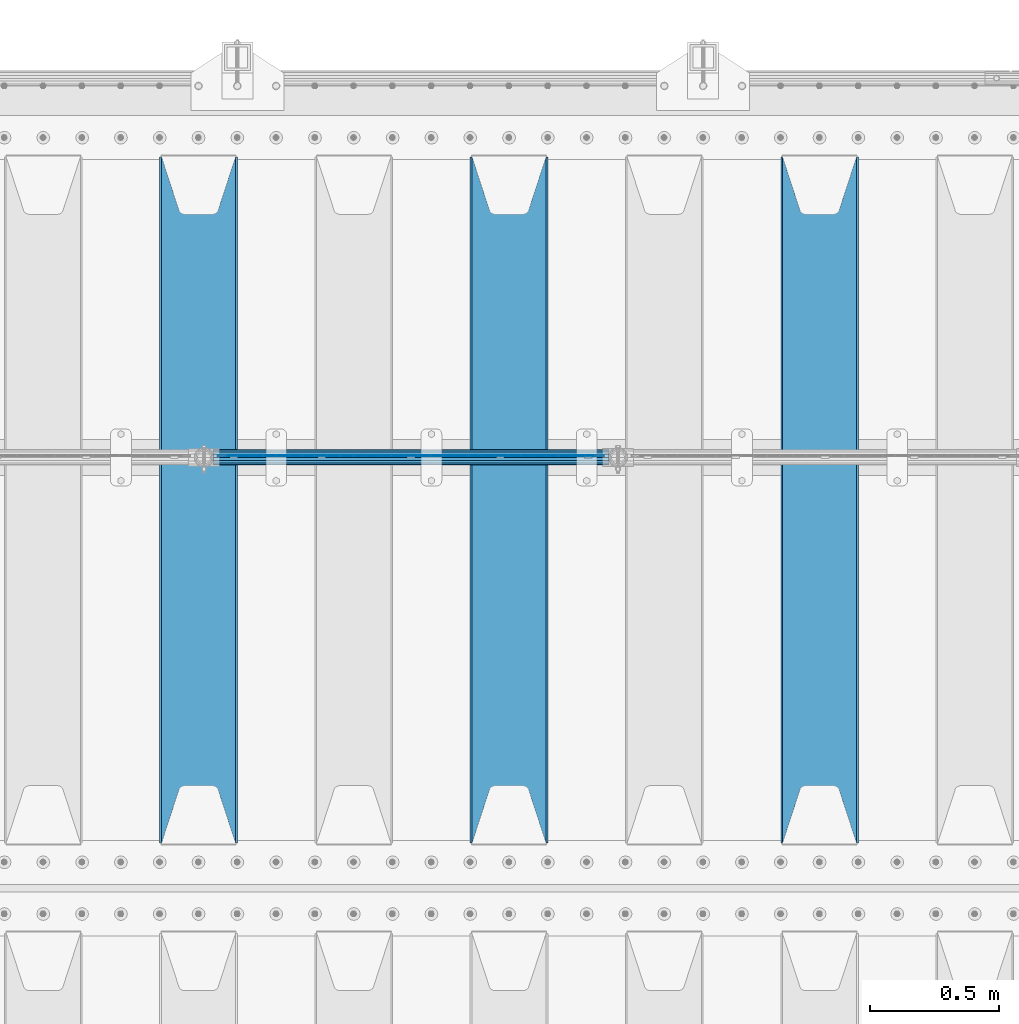
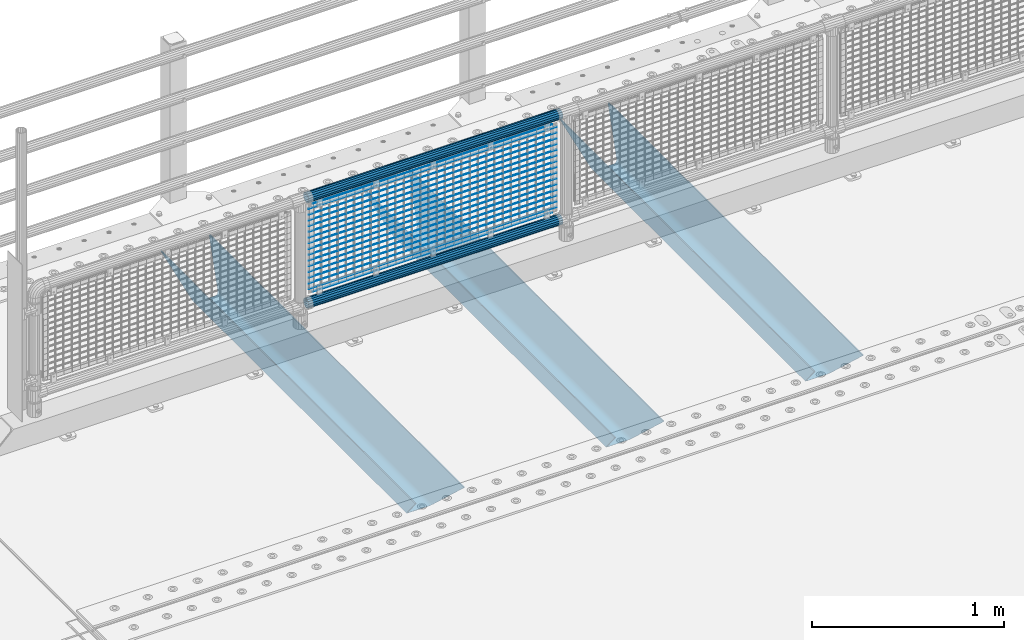
# One storey, part 121 of 247: 22 beams.
"""IFC2X3 building model written with IfcOpenShell, lengths in millimetres."""

from ifc_helpers import new_model, si_unit, frame, origin_with_axes, place, context, subcontext, project, spatial, faceted_brep, material, type_object, element, save


model = new_model("IFC2X3")

# Units and contexts
model_context = context("Model", 3, precision=1e-05, world=origin_with_axes())
body_context = subcontext(model_context, "Body", "Model", "MODEL_VIEW")
ifc_project = project(units=[si_unit("LENGTHUNIT", "METRE", prefix="MILLI"), si_unit("AREAUNIT", "SQUARE_METRE"), si_unit("VOLUMEUNIT", "CUBIC_METRE"), si_unit("MASSUNIT", "GRAM", prefix="KILO"), si_unit("TIMEUNIT", "SECOND"), si_unit("PLANEANGLEUNIT", "RADIAN"), si_unit("SOLIDANGLEUNIT", "STERADIAN"), si_unit("THERMODYNAMICTEMPERATUREUNIT", "DEGREE_CELSIUS"), si_unit("LUMINOUSINTENSITYUNIT", "LUMEN")], contexts=[model_context])

# Site, building, storey
site_placement = place(None, origin_with_axes())
site = spatial("IfcSite", under=ifc_project, at=site_placement, CompositionType="ELEMENT")
building_placement = place(site_placement, origin_with_axes())
building = spatial("IfcBuilding", under=site, at=building_placement, Name="Standard", CompositionType="ELEMENT")
storey_placement = place(building_placement, origin_with_axes())
storey = spatial("IfcBuildingStorey", under=building, at=storey_placement, Name="Undefined", CompositionType="ELEMENT", Elevation=0.0)

# Beams
ifc_material_1 = material(Name="STEEL/S355N")
beam_type_1 = type_object("IfcBeamType", PredefinedType="NOTDEFINED")
beam_1_placement = place(storey_placement, frame((4600.0, 6175.0, -115.0), z_axis=(0.0, 0.0, 1.0), x_axis=(0.0, 1.0, 0.0)))
element("IfcBeam", 1, at=beam_1_placement, inside=storey, type_object=beam_type_1, material=ifc_material_1, context=body_context, shape_type="Brep", body=[
    faceted_brep([(0.0, 150.0, 115.0), (0.0, 143.689999999999, 115.0), (2650.00000000297, 143.689999999999, 115.0), (2650.00000000297, 150.0, 115.0), (2650.00000000297, 142.059565218402, 110.0000000031), (2650.00000000297, 148.369565218403, 110.0000000031), (2441.90079219208, -80.1103600731112, -98.0992078077845), (2437.7588105432, -77.5672621345584, -102.241189456673), (2434.06523489746, -74.4080125315522, -105.934765102404), (2430.91086095089, -70.710272125576, -109.089139048974), (2428.37322971128, -66.5649389910068, -111.626770288588), (2426.51472138054, -62.0739139532889, -113.485278619323), (2425.38102192091, -57.3475956567672, -114.618978078955), (2424.99999999987, -52.5021667386536, -115.0), (2424.99999999987, 52.5021667386536, -115.0), (2425.38102192091, 57.3475956567672, -114.618978078955), (2426.51472138054, 62.0739139532889, -113.485278619323), (2428.37322971128, 66.5649389910068, -111.626770288588), (2430.91086095089, 70.710272125576, -109.089139048974), (2434.06523489746, 74.4080125315522, -105.934765102404), (2437.7588105432, 77.5672621345584, -102.241189456673), (2441.90079219208, 80.1103600731112, -98.0992078077846), (2446.38936140511, 81.9747917625791, -93.6106385947584), (2448.24948500409, 76.2713538057251, -91.7505149957729), (2444.62967112262, 74.76777986261, -95.3703288772456), (2441.28936334126, 72.7168944282894, -98.710636658607), (2438.31067330438, 70.1691124903846, -101.689326695487), (2435.76682334747, 67.1870637758839, -104.233176652398), (2433.72034654133, 63.8440531834895, -106.279653458539), (2432.22154950041, 60.222258798236, -107.778450499454), (2431.30727574265, 56.4107117849089, -108.692724257221), (2430.99999999987, 52.5031078186876, -109.0), (2430.99999999987, -52.5031078186876, -109.0), (2431.30727574265, -56.4107117849089, -108.692724257221), (2432.22154950041, -60.222258798236, -107.778450499454), (2433.72034654133, -63.8440531834895, -106.279653458539), (2435.76682334747, -67.1870637758839, -104.233176652398), (2438.31067330438, -70.1691124903846, -101.689326695487), (2441.28936334126, -72.7168944282894, -98.7106366586071), (2444.62967112262, -74.76777986261, -95.3703288772457), (2448.24948500409, -76.2713538057251, -91.7505149957729), (2650.00000000297, -142.059565218402, 110.0000000031), (2650.00000000297, -148.369565218403, 110.0000000031), (2446.38936140511, -81.9747917625791, -93.6106385947584), (2650.00000000297, -143.689999999999, 115.0), (2650.00000000297, -150.0, 115.0), (0.0, -143.689999999999, 115.0), (0.0, -150.0, 115.0), (0.0, -148.369565218261, 110.000000002663), (203.610638597422, -81.9747917625791, -93.6106385947584), (208.099207810448, -80.1103600731112, -98.0992078077845), (212.241189459336, -77.5672621345584, -102.241189456673), (215.934765105068, -74.4080125315522, -105.934765102404), (219.089139051637, -70.710272125576, -109.089139048974), (221.626770291251, -66.5649389910068, -111.626770288588), (223.485278621985, -62.0739139532889, -113.485278619323), (224.618978081617, -57.3475956567672, -114.618978078955), (225.000000002663, -52.5021667386536, -115.0), (225.000000002663, 52.5021667386536, -115.0), (224.618978081617, 57.3475956567672, -114.618978078955), (223.485278621985, 62.0739139532889, -113.485278619323), (221.626770291251, 66.5649389910068, -111.626770288588), (219.089139051637, 70.710272125576, -109.089139048974), (215.934765105068, 74.4080125315522, -105.934765102404), (212.241189459336, 77.5672621345584, -102.241189456673), (208.099207810448, 80.1103600731112, -98.0992078077846), (203.610638597422, 81.9747917625791, -93.6106385947584), (0.0, 148.369565218261, 110.000000002663), (0.0, 142.05956521826, 110.000000002663), (201.750514998436, 76.2713538057251, -91.7505149957729), (205.370328879908, 74.76777986261, -95.3703288772456), (208.710636661271, 72.7168944282894, -98.710636658607), (211.68932669815, 70.1691124903846, -101.689326695487), (214.233176655061, 67.1870637758839, -104.233176652398), (216.279653461202, 63.8440531834895, -106.279653458539), (217.778450502117, 60.222258798236, -107.778450499454), (218.692724259885, 56.4107117849089, -108.692724257221), (219.000000002663, 52.5031078186876, -109.0), (219.000000002663, -52.5031078186876, -109.0), (218.692724259885, -56.4107117849089, -108.692724257221), (217.778450502117, -60.222258798236, -107.778450499454), (216.279653461202, -63.8440531834895, -106.279653458539), (214.233176655061, -67.1870637758839, -104.233176652398), (211.68932669815, -70.1691124903846, -101.689326695487), (208.710636661271, -72.7168944282894, -98.7106366586071), (205.370328879908, -74.76777986261, -95.3703288772457), (201.750514998436, -76.2713538057251, -91.7505149957729), (0.0, -142.05956521826, 110.000000002663)], [[[0, 1, 2, 3]], [[3, 2, 4, 5]], [[6, 7, 8, 9, 10, 11, 12, 13, 14, 15, 16, 17, 18, 19, 20, 21, 22, 5, 4, 23, 24, 25, 26, 27, 28, 29, 30, 31, 32, 33, 34, 35, 36, 37, 38, 39, 40, 41, 42, 43]], [[44, 45, 42, 41]], [[46, 47, 45, 44]], [[43, 42, 45, 47, 48, 49]], [[6, 43, 49, 50]], [[7, 6, 50, 51]], [[8, 7, 51, 52]], [[9, 8, 52, 53]], [[10, 9, 53, 54]], [[11, 10, 54, 55]], [[12, 11, 55, 56]], [[13, 12, 56, 57]], [[14, 13, 57, 58]], [[15, 14, 58, 59]], [[16, 15, 59, 60]], [[17, 16, 60, 61]], [[18, 17, 61, 62]], [[19, 18, 62, 63]], [[20, 19, 63, 64]], [[21, 20, 64, 65]], [[22, 21, 65, 66]], [[0, 3, 5, 22, 66, 67]], [[1, 0, 67, 68]], [[23, 4, 2, 1, 68, 69]], [[24, 23, 69, 70]], [[25, 24, 70, 71]], [[26, 25, 71, 72]], [[27, 26, 72, 73]], [[28, 27, 73, 74]], [[29, 28, 74, 75]], [[30, 29, 75, 76]], [[31, 30, 76, 77]], [[32, 31, 77, 78]], [[33, 32, 78, 79]], [[34, 33, 79, 80]], [[35, 34, 80, 81]], [[36, 35, 81, 82]], [[37, 36, 82, 83]], [[38, 37, 83, 84]], [[39, 38, 84, 85]], [[40, 39, 85, 86]], [[46, 44, 41, 40, 86, 87]], [[47, 46, 87, 48]], [[86, 85, 84, 83, 82, 81, 80, 79, 78, 77, 76, 75, 74, 73, 72, 71, 70, 69, 68, 67, 66, 65, 64, 63, 62, 61, 60, 59, 58, 57, 56, 55, 54, 53, 52, 51, 50, 49, 48, 87]]]),
])
beam_2_placement = place(storey_placement, frame((3400.0, 6175.0, -115.0), z_axis=(0.0, 0.0, 1.0), x_axis=(0.0, 1.0, 0.0)))
element("IfcBeam", 2, at=beam_2_placement, inside=storey, type_object=beam_type_1, material=ifc_material_1, context=body_context, shape_type="Brep", body=[
    faceted_brep([(0.0, 150.0, 115.0), (0.0, 143.689999999999, 115.0), (2650.00000000297, 143.689999999999, 115.0), (2650.00000000297, 150.0, 115.0), (2650.00000000297, 142.059565218402, 110.0000000031), (2650.00000000297, 148.369565218403, 110.0000000031), (2441.90079219208, -80.1103600731112, -98.0992078077845), (2437.7588105432, -77.5672621345584, -102.241189456673), (2434.06523489746, -74.4080125315522, -105.934765102404), (2430.91086095089, -70.710272125576, -109.089139048974), (2428.37322971128, -66.5649389910068, -111.626770288588), (2426.51472138054, -62.0739139532889, -113.485278619323), (2425.38102192091, -57.3475956567672, -114.618978078955), (2424.99999999987, -52.5021667386536, -115.0), (2424.99999999987, 52.5021667386536, -115.0), (2425.38102192091, 57.3475956567672, -114.618978078955), (2426.51472138054, 62.0739139532889, -113.485278619323), (2428.37322971128, 66.5649389910068, -111.626770288588), (2430.91086095089, 70.710272125576, -109.089139048974), (2434.06523489746, 74.4080125315522, -105.934765102404), (2437.7588105432, 77.5672621345584, -102.241189456673), (2441.90079219208, 80.1103600731112, -98.0992078077846), (2446.38936140511, 81.9747917625791, -93.6106385947584), (2448.24948500409, 76.2713538057251, -91.7505149957729), (2444.62967112262, 74.76777986261, -95.3703288772456), (2441.28936334126, 72.7168944282894, -98.710636658607), (2438.31067330438, 70.1691124903846, -101.689326695487), (2435.76682334747, 67.1870637758839, -104.233176652398), (2433.72034654133, 63.8440531834895, -106.279653458539), (2432.22154950041, 60.222258798236, -107.778450499454), (2431.30727574265, 56.4107117849089, -108.692724257221), (2430.99999999987, 52.5031078186876, -109.0), (2430.99999999987, -52.5031078186876, -109.0), (2431.30727574265, -56.4107117849089, -108.692724257221), (2432.22154950041, -60.222258798236, -107.778450499454), (2433.72034654133, -63.8440531834895, -106.279653458539), (2435.76682334747, -67.1870637758839, -104.233176652398), (2438.31067330438, -70.1691124903846, -101.689326695487), (2441.28936334126, -72.7168944282894, -98.7106366586071), (2444.62967112262, -74.76777986261, -95.3703288772457), (2448.24948500409, -76.2713538057251, -91.7505149957729), (2650.00000000297, -142.059565218402, 110.0000000031), (2650.00000000297, -148.369565218403, 110.0000000031), (2446.38936140511, -81.9747917625791, -93.6106385947584), (2650.00000000297, -143.689999999999, 115.0), (2650.00000000297, -150.0, 115.0), (0.0, -143.689999999999, 115.0), (0.0, -150.0, 115.0), (0.0, -148.369565218261, 110.000000002663), (203.610638597422, -81.9747917625791, -93.6106385947584), (208.099207810448, -80.1103600731112, -98.0992078077845), (212.241189459336, -77.5672621345584, -102.241189456673), (215.934765105068, -74.4080125315522, -105.934765102404), (219.089139051637, -70.710272125576, -109.089139048974), (221.626770291251, -66.5649389910068, -111.626770288588), (223.485278621985, -62.0739139532889, -113.485278619323), (224.618978081617, -57.3475956567672, -114.618978078955), (225.000000002663, -52.5021667386536, -115.0), (225.000000002663, 52.5021667386536, -115.0), (224.618978081617, 57.3475956567672, -114.618978078955), (223.485278621985, 62.0739139532889, -113.485278619323), (221.626770291251, 66.5649389910068, -111.626770288588), (219.089139051637, 70.710272125576, -109.089139048974), (215.934765105068, 74.4080125315522, -105.934765102404), (212.241189459336, 77.5672621345584, -102.241189456673), (208.099207810448, 80.1103600731112, -98.0992078077846), (203.610638597422, 81.9747917625791, -93.6106385947584), (0.0, 148.369565218261, 110.000000002663), (0.0, 142.05956521826, 110.000000002663), (201.750514998436, 76.2713538057251, -91.7505149957729), (205.370328879908, 74.76777986261, -95.3703288772456), (208.710636661271, 72.7168944282894, -98.710636658607), (211.68932669815, 70.1691124903846, -101.689326695487), (214.233176655061, 67.1870637758839, -104.233176652398), (216.279653461202, 63.8440531834895, -106.279653458539), (217.778450502117, 60.222258798236, -107.778450499454), (218.692724259885, 56.4107117849089, -108.692724257221), (219.000000002663, 52.5031078186876, -109.0), (219.000000002663, -52.5031078186876, -109.0), (218.692724259885, -56.4107117849089, -108.692724257221), (217.778450502117, -60.222258798236, -107.778450499454), (216.279653461202, -63.8440531834895, -106.279653458539), (214.233176655061, -67.1870637758839, -104.233176652398), (211.68932669815, -70.1691124903846, -101.689326695487), (208.710636661271, -72.7168944282894, -98.7106366586071), (205.370328879908, -74.76777986261, -95.3703288772457), (201.750514998436, -76.2713538057251, -91.7505149957729), (0.0, -142.05956521826, 110.000000002663)], [[[0, 1, 2, 3]], [[3, 2, 4, 5]], [[6, 7, 8, 9, 10, 11, 12, 13, 14, 15, 16, 17, 18, 19, 20, 21, 22, 5, 4, 23, 24, 25, 26, 27, 28, 29, 30, 31, 32, 33, 34, 35, 36, 37, 38, 39, 40, 41, 42, 43]], [[44, 45, 42, 41]], [[46, 47, 45, 44]], [[43, 42, 45, 47, 48, 49]], [[6, 43, 49, 50]], [[7, 6, 50, 51]], [[8, 7, 51, 52]], [[9, 8, 52, 53]], [[10, 9, 53, 54]], [[11, 10, 54, 55]], [[12, 11, 55, 56]], [[13, 12, 56, 57]], [[14, 13, 57, 58]], [[15, 14, 58, 59]], [[16, 15, 59, 60]], [[17, 16, 60, 61]], [[18, 17, 61, 62]], [[19, 18, 62, 63]], [[20, 19, 63, 64]], [[21, 20, 64, 65]], [[22, 21, 65, 66]], [[0, 3, 5, 22, 66, 67]], [[1, 0, 67, 68]], [[23, 4, 2, 1, 68, 69]], [[24, 23, 69, 70]], [[25, 24, 70, 71]], [[26, 25, 71, 72]], [[27, 26, 72, 73]], [[28, 27, 73, 74]], [[29, 28, 74, 75]], [[30, 29, 75, 76]], [[31, 30, 76, 77]], [[32, 31, 77, 78]], [[33, 32, 78, 79]], [[34, 33, 79, 80]], [[35, 34, 80, 81]], [[36, 35, 81, 82]], [[37, 36, 82, 83]], [[38, 37, 83, 84]], [[39, 38, 84, 85]], [[40, 39, 85, 86]], [[46, 44, 41, 40, 86, 87]], [[47, 46, 87, 48]], [[86, 85, 84, 83, 82, 81, 80, 79, 78, 77, 76, 75, 74, 73, 72, 71, 70, 69, 68, 67, 66, 65, 64, 63, 62, 61, 60, 59, 58, 57, 56, 55, 54, 53, 52, 51, 50, 49, 48, 87]]]),
])
beam_3_placement = place(storey_placement, frame((2200.0, 6175.0, -115.0), z_axis=(0.0, 0.0, 1.0), x_axis=(0.0, 1.0, 0.0)))
element("IfcBeam", 3, at=beam_3_placement, inside=storey, type_object=beam_type_1, material=ifc_material_1, context=body_context, shape_type="Brep", body=[
    faceted_brep([(0.0, 150.0, 115.0), (0.0, 143.689999999999, 115.0), (2650.00000000297, 143.689999999999, 115.0), (2650.00000000297, 150.0, 115.0), (2650.00000000297, 142.059565218402, 110.0000000031), (2650.00000000297, 148.369565218403, 110.0000000031), (2441.90079219208, -80.1103600731112, -98.0992078077845), (2437.7588105432, -77.5672621345584, -102.241189456673), (2434.06523489746, -74.4080125315522, -105.934765102404), (2430.91086095089, -70.710272125576, -109.089139048974), (2428.37322971128, -66.5649389910068, -111.626770288588), (2426.51472138054, -62.0739139532889, -113.485278619323), (2425.38102192091, -57.3475956567672, -114.618978078955), (2424.99999999987, -52.5021667386536, -115.0), (2424.99999999987, 52.5021667386536, -115.0), (2425.38102192091, 57.3475956567672, -114.618978078955), (2426.51472138054, 62.0739139532889, -113.485278619323), (2428.37322971128, 66.5649389910068, -111.626770288588), (2430.91086095089, 70.710272125576, -109.089139048974), (2434.06523489746, 74.4080125315522, -105.934765102404), (2437.7588105432, 77.5672621345584, -102.241189456673), (2441.90079219208, 80.1103600731112, -98.0992078077846), (2446.38936140511, 81.9747917625791, -93.6106385947584), (2448.24948500409, 76.2713538057251, -91.7505149957729), (2444.62967112262, 74.76777986261, -95.3703288772456), (2441.28936334126, 72.7168944282894, -98.710636658607), (2438.31067330438, 70.1691124903846, -101.689326695487), (2435.76682334747, 67.1870637758839, -104.233176652398), (2433.72034654133, 63.8440531834895, -106.279653458539), (2432.22154950041, 60.222258798236, -107.778450499454), (2431.30727574265, 56.4107117849089, -108.692724257221), (2430.99999999987, 52.5031078186876, -109.0), (2430.99999999987, -52.5031078186876, -109.0), (2431.30727574265, -56.4107117849089, -108.692724257221), (2432.22154950041, -60.222258798236, -107.778450499454), (2433.72034654133, -63.8440531834895, -106.279653458539), (2435.76682334747, -67.1870637758839, -104.233176652398), (2438.31067330438, -70.1691124903846, -101.689326695487), (2441.28936334126, -72.7168944282894, -98.7106366586071), (2444.62967112262, -74.76777986261, -95.3703288772457), (2448.24948500409, -76.2713538057251, -91.7505149957729), (2650.00000000297, -142.059565218402, 110.0000000031), (2650.00000000297, -148.369565218403, 110.0000000031), (2446.38936140511, -81.9747917625791, -93.6106385947584), (2650.00000000297, -143.689999999999, 115.0), (2650.00000000297, -150.0, 115.0), (0.0, -143.689999999999, 115.0), (0.0, -150.0, 115.0), (0.0, -148.369565218261, 110.000000002663), (203.610638597422, -81.9747917625791, -93.6106385947584), (208.099207810448, -80.1103600731112, -98.0992078077845), (212.241189459336, -77.5672621345584, -102.241189456673), (215.934765105068, -74.4080125315522, -105.934765102404), (219.089139051637, -70.710272125576, -109.089139048974), (221.626770291251, -66.5649389910068, -111.626770288588), (223.485278621985, -62.0739139532889, -113.485278619323), (224.618978081617, -57.3475956567672, -114.618978078955), (225.000000002663, -52.5021667386536, -115.0), (225.000000002663, 52.5021667386536, -115.0), (224.618978081617, 57.3475956567672, -114.618978078955), (223.485278621985, 62.0739139532889, -113.485278619323), (221.626770291251, 66.5649389910068, -111.626770288588), (219.089139051637, 70.710272125576, -109.089139048974), (215.934765105068, 74.4080125315522, -105.934765102404), (212.241189459336, 77.5672621345584, -102.241189456673), (208.099207810448, 80.1103600731112, -98.0992078077846), (203.610638597422, 81.9747917625791, -93.6106385947584), (0.0, 148.369565218261, 110.000000002663), (0.0, 142.05956521826, 110.000000002663), (201.750514998436, 76.2713538057251, -91.7505149957729), (205.370328879908, 74.76777986261, -95.3703288772456), (208.710636661271, 72.7168944282894, -98.710636658607), (211.68932669815, 70.1691124903846, -101.689326695487), (214.233176655061, 67.1870637758839, -104.233176652398), (216.279653461202, 63.8440531834895, -106.279653458539), (217.778450502117, 60.222258798236, -107.778450499454), (218.692724259885, 56.4107117849089, -108.692724257221), (219.000000002663, 52.5031078186876, -109.0), (219.000000002663, -52.5031078186876, -109.0), (218.692724259885, -56.4107117849089, -108.692724257221), (217.778450502117, -60.222258798236, -107.778450499454), (216.279653461202, -63.8440531834895, -106.279653458539), (214.233176655061, -67.1870637758839, -104.233176652398), (211.68932669815, -70.1691124903846, -101.689326695487), (208.710636661271, -72.7168944282894, -98.7106366586071), (205.370328879908, -74.76777986261, -95.3703288772457), (201.750514998436, -76.2713538057251, -91.7505149957729), (0.0, -142.05956521826, 110.000000002663)], [[[0, 1, 2, 3]], [[3, 2, 4, 5]], [[6, 7, 8, 9, 10, 11, 12, 13, 14, 15, 16, 17, 18, 19, 20, 21, 22, 5, 4, 23, 24, 25, 26, 27, 28, 29, 30, 31, 32, 33, 34, 35, 36, 37, 38, 39, 40, 41, 42, 43]], [[44, 45, 42, 41]], [[46, 47, 45, 44]], [[43, 42, 45, 47, 48, 49]], [[6, 43, 49, 50]], [[7, 6, 50, 51]], [[8, 7, 51, 52]], [[9, 8, 52, 53]], [[10, 9, 53, 54]], [[11, 10, 54, 55]], [[12, 11, 55, 56]], [[13, 12, 56, 57]], [[14, 13, 57, 58]], [[15, 14, 58, 59]], [[16, 15, 59, 60]], [[17, 16, 60, 61]], [[18, 17, 61, 62]], [[19, 18, 62, 63]], [[20, 19, 63, 64]], [[21, 20, 64, 65]], [[22, 21, 65, 66]], [[0, 3, 5, 22, 66, 67]], [[1, 0, 67, 68]], [[23, 4, 2, 1, 68, 69]], [[24, 23, 69, 70]], [[25, 24, 70, 71]], [[26, 25, 71, 72]], [[27, 26, 72, 73]], [[28, 27, 73, 74]], [[29, 28, 74, 75]], [[30, 29, 75, 76]], [[31, 30, 76, 77]], [[32, 31, 77, 78]], [[33, 32, 78, 79]], [[34, 33, 79, 80]], [[35, 34, 80, 81]], [[36, 35, 81, 82]], [[37, 36, 82, 83]], [[38, 37, 83, 84]], [[39, 38, 84, 85]], [[40, 39, 85, 86]], [[46, 44, 41, 40, 86, 87]], [[47, 46, 87, 48]], [[86, 85, 84, 83, 82, 81, 80, 79, 78, 77, 76, 75, 74, 73, 72, 71, 70, 69, 68, 67, 66, 65, 64, 63, 62, 61, 60, 59, 58, 57, 56, 55, 54, 53, 52, 51, 50, 49, 48, 87]]]),
])
ifc_material_2 = material()
beam_type_2 = type_object("IfcBeamType", PredefinedType="NOTDEFINED")
beam_4_placement = place(storey_placement, frame((2255.85000000001, 7664.5, 298.170000000001), z_axis=(0.0, 0.0, 1.0), x_axis=(1.0, 0.0, 0.0)))
element("IfcBeam", 4, at=beam_4_placement, inside=storey, type_object=beam_type_2, material=ifc_material_2, context=body_context, shape_type="Brep", body=[
    faceted_brep([(0.0, -25.3500000000004, 0.0), (0.0, -23.4203461491616, 9.70102501045585), (1530.0, -23.4203461491616, 9.70102501045506), (1530.0, -25.3500000000004, 0.0), (0.0, -17.9251569030794, 17.9251569030785), (1530.0, -17.9251569030794, 17.925156903079), (0.0, -9.70102501045494, 23.4203461491616), (1530.0, -9.70102501045494, 23.4203461491611), (0.0, 0.0, 25.3500000000004), (1530.0, 0.0, 25.35), (0.0, 9.70102501045494, 23.4203461491616), (1530.0, 9.70102501045494, 23.4203461491611), (0.0, 17.9251569030794, 17.9251569030785), (1530.0, 17.9251569030794, 17.925156903079), (0.0, 23.4203461491616, 9.70102501045585), (1530.0, 23.4203461491616, 9.70102501045506), (0.0, 25.3500000000004, 0.0), (1530.0, 25.3500000000004, 0.0), (0.0, 23.4203461491616, -9.70102501045585), (1530.0, 23.4203461491616, -9.70102501045506), (0.0, 17.9251569030794, -17.9251569030785), (1530.0, 17.9251569030794, -17.925156903079), (0.0, 9.70102501045494, -23.4203461491616), (1530.0, 9.70102501045494, -23.4203461491611), (0.0, 0.0, -25.3500000000004), (1530.0, 0.0, -25.35), (0.0, -9.70102501045494, -23.4203461491616), (1530.0, -9.70102501045494, -23.4203461491611), (0.0, -17.9251569030794, -17.9251569030785), (1530.0, -17.9251569030794, -17.925156903079), (0.0, -23.4203461491616, -9.70102501045585), (1530.0, -23.4203461491616, -9.70102501045506), (0.0, -30.1499999999996, 0.0), (0.0, -27.8549679052148, -11.5379054858076), (1530.0, -27.8549679052148, -11.5379054858075), (1530.0, -30.1499999999996, 0.0), (0.0, -21.3192694527743, -21.3192694527752), (1530.0, -21.3192694527743, -21.3192694527744), (0.0, -11.5379054858076, -27.8549679052157), (1530.0, -11.5379054858076, -27.8549679052153), (0.0, 0.0, -30.1499999999996), (1530.0, 0.0, -30.15), (0.0, 11.5379054858076, -27.8549679052157), (1530.0, 11.5379054858076, -27.8549679052153), (0.0, 21.3192694527743, -21.3192694527752), (1530.0, 21.3192694527743, -21.3192694527744), (0.0, 27.8549679052157, -11.5379054858076), (1530.0, 27.8549679052157, -11.5379054858074), (0.0, 30.1499999999996, 0.0), (1530.0, 30.1499999999996, 0.0), (0.0, 27.8549679052157, 11.5379054858076), (1530.0, 27.8549679052157, 11.5379054858074), (0.0, 21.3192694527743, 21.3192694527752), (1530.0, 21.3192694527743, 21.3192694527744), (0.0, 11.5379054858076, 27.8549679052157), (1530.0, 11.5379054858076, 27.8549679052153), (0.0, 0.0, 30.1499999999996), (1530.0, 0.0, 30.15), (0.0, -11.5379054858076, 27.8549679052157), (1530.0, -11.5379054858076, 27.8549679052153), (0.0, -21.3192694527743, 21.3192694527752), (1530.0, -21.3192694527743, 21.3192694527744), (0.0, -27.8549679052157, 11.5379054858076), (1530.0, -27.8549679052157, 11.5379054858074)], [[[0, 1, 2, 3]], [[1, 4, 5, 2]], [[4, 6, 7, 5]], [[6, 8, 9, 7]], [[8, 10, 11, 9]], [[10, 12, 13, 11]], [[12, 14, 15, 13]], [[14, 16, 17, 15]], [[16, 18, 19, 17]], [[18, 20, 21, 19]], [[20, 22, 23, 21]], [[22, 24, 25, 23]], [[24, 26, 27, 25]], [[26, 28, 29, 27]], [[28, 30, 31, 29]], [[30, 0, 3, 31]], [[32, 33, 34, 35]], [[33, 36, 37, 34]], [[36, 38, 39, 37]], [[38, 40, 41, 39]], [[40, 42, 43, 41]], [[42, 44, 45, 43]], [[44, 46, 47, 45]], [[46, 48, 49, 47]], [[48, 50, 51, 49]], [[50, 52, 53, 51]], [[52, 54, 55, 53]], [[54, 56, 57, 55]], [[56, 58, 59, 57]], [[58, 60, 61, 59]], [[60, 62, 63, 61]], [[62, 32, 35, 63]], [[37, 39, 41, 43, 45, 47, 49, 51, 53, 55, 57, 59, 61, 63, 35, 34], [5, 7, 9, 11, 13, 15, 17, 19, 21, 23, 25, 27, 29, 31, 3, 2]], [[62, 60, 58, 56, 54, 52, 50, 48, 46, 44, 42, 40, 38, 36, 33, 32], [30, 28, 26, 24, 22, 20, 18, 16, 14, 12, 10, 8, 6, 4, 1, 0]]]),
])
beam_5_placement = place(storey_placement, frame((2255.85, 7664.5, 969.849999999999), z_axis=(0.0, 0.0, 1.0), x_axis=(1.0, 0.0, 0.0)))
element("IfcBeam", 5, at=beam_5_placement, inside=storey, type_object=beam_type_2, material=ifc_material_2, context=body_context, shape_type="Brep", body=[
    faceted_brep([(0.0, -25.3500000000004, 0.0), (0.0, -23.4203461491616, 9.70102501045585), (1530.0, -23.4203461491616, 9.70102501045506), (1530.0, -25.3500000000004, 0.0), (0.0, -17.9251569030794, 17.9251569030785), (1530.0, -17.9251569030794, 17.925156903079), (0.0, -9.70102501045494, 23.4203461491616), (1530.0, -9.70102501045494, 23.4203461491611), (0.0, 0.0, 25.3500000000004), (1530.0, 0.0, 25.35), (0.0, 9.70102501045494, 23.4203461491616), (1530.0, 9.70102501045494, 23.4203461491611), (0.0, 17.9251569030794, 17.9251569030785), (1530.0, 17.9251569030794, 17.925156903079), (0.0, 23.4203461491616, 9.70102501045585), (1530.0, 23.4203461491616, 9.70102501045506), (0.0, 25.3500000000004, 0.0), (1530.0, 25.3500000000004, 0.0), (0.0, 23.4203461491616, -9.70102501045585), (1530.0, 23.4203461491616, -9.70102501045506), (0.0, 17.9251569030794, -17.9251569030785), (1530.0, 17.9251569030794, -17.925156903079), (0.0, 9.70102501045494, -23.4203461491616), (1530.0, 9.70102501045494, -23.4203461491611), (0.0, 0.0, -25.3500000000004), (1530.0, 0.0, -25.35), (0.0, -9.70102501045494, -23.4203461491616), (1530.0, -9.70102501045494, -23.4203461491611), (0.0, -17.9251569030794, -17.9251569030785), (1530.0, -17.9251569030794, -17.925156903079), (0.0, -23.4203461491616, -9.70102501045585), (1530.0, -23.4203461491616, -9.70102501045506), (0.0, -30.1499999999996, 0.0), (0.0, -27.8549679052148, -11.5379054858076), (1530.0, -27.8549679052148, -11.5379054858075), (1530.0, -30.1499999999996, 0.0), (0.0, -21.3192694527743, -21.3192694527752), (1530.0, -21.3192694527743, -21.3192694527744), (0.0, -11.5379054858076, -27.8549679052157), (1530.0, -11.5379054858076, -27.8549679052153), (0.0, 0.0, -30.1499999999996), (1530.0, 0.0, -30.15), (0.0, 11.5379054858076, -27.8549679052157), (1530.0, 11.5379054858076, -27.8549679052153), (0.0, 21.3192694527743, -21.3192694527752), (1530.0, 21.3192694527743, -21.3192694527744), (0.0, 27.8549679052157, -11.5379054858076), (1530.0, 27.8549679052157, -11.5379054858074), (0.0, 30.1499999999996, 0.0), (1530.0, 30.1499999999996, 0.0), (0.0, 27.8549679052157, 11.5379054858076), (1530.0, 27.8549679052157, 11.5379054858074), (0.0, 21.3192694527743, 21.3192694527752), (1530.0, 21.3192694527743, 21.3192694527744), (0.0, 11.5379054858076, 27.8549679052157), (1530.0, 11.5379054858076, 27.8549679052153), (0.0, 0.0, 30.1499999999996), (1530.0, 0.0, 30.15), (0.0, -11.5379054858076, 27.8549679052157), (1530.0, -11.5379054858076, 27.8549679052153), (0.0, -21.3192694527743, 21.3192694527752), (1530.0, -21.3192694527743, 21.3192694527744), (0.0, -27.8549679052157, 11.5379054858076), (1530.0, -27.8549679052157, 11.5379054858074)], [[[0, 1, 2, 3]], [[1, 4, 5, 2]], [[4, 6, 7, 5]], [[6, 8, 9, 7]], [[8, 10, 11, 9]], [[10, 12, 13, 11]], [[12, 14, 15, 13]], [[14, 16, 17, 15]], [[16, 18, 19, 17]], [[18, 20, 21, 19]], [[20, 22, 23, 21]], [[22, 24, 25, 23]], [[24, 26, 27, 25]], [[26, 28, 29, 27]], [[28, 30, 31, 29]], [[30, 0, 3, 31]], [[32, 33, 34, 35]], [[33, 36, 37, 34]], [[36, 38, 39, 37]], [[38, 40, 41, 39]], [[40, 42, 43, 41]], [[42, 44, 45, 43]], [[44, 46, 47, 45]], [[46, 48, 49, 47]], [[48, 50, 51, 49]], [[50, 52, 53, 51]], [[52, 54, 55, 53]], [[54, 56, 57, 55]], [[56, 58, 59, 57]], [[58, 60, 61, 59]], [[60, 62, 63, 61]], [[62, 32, 35, 63]], [[37, 39, 41, 43, 45, 47, 49, 51, 53, 55, 57, 59, 61, 63, 35, 34], [5, 7, 9, 11, 13, 15, 17, 19, 21, 23, 25, 27, 29, 31, 3, 2]], [[62, 60, 58, 56, 54, 52, 50, 48, 46, 44, 42, 40, 38, 36, 33, 32], [30, 28, 26, 24, 22, 20, 18, 16, 14, 12, 10, 8, 6, 4, 1, 0]]]),
])
ifc_material_3 = material(Name="Misc_Undefined")
beam_type_3 = type_object("IfcBeamType", Name="D3", PredefinedType="NOTDEFINED")
for number, where, z_axis, x_axis in (
    (6, (2276.0, 7670.5, 851.596999999999), (0.0, 0.0, 1.0), (1.0, 0.0, 0.0)),
    (7, (2276.0, 7670.5, 669.452), (0.0, 0.0, 1.0), (1.0, 0.0, 0.0)),
    (8, (2276.0, 7670.5, 523.736), (0.0, 0.0, 1.0), (1.0, 0.0, 0.0)),
    (9, (2276.0, 7670.5, 487.307), (0.0, 0.0, 1.0), (1.0, 0.0, 0.0)),
    (10, (2276.0, 7670.5, 705.881), (0.0, 0.0, 1.0), (1.0, 0.0, 0.0)),
    (11, (2276.0, 7670.5, 596.594), (0.0, 0.0, 1.0), (1.0, 0.0, 0.0)),
    (12, (2276.0, 7670.5, 450.878), (0.0, 0.0, 1.0), (1.0, 0.0, 0.0)),
    (13, (2276.0, 7670.5, 815.167999999999), (0.0, 0.0, 1.0), (1.0, 0.0, 0.0)),
    (14, (2276.0, 7670.5, 888.025999999999), (0.0, 0.0, 1.0), (1.0, 0.0, 0.0)),
    (15, (2276.0, 7670.5, 778.738999999999), (0.0, 0.0, 1.0), (1.0, 0.0, 0.0)),
    (16, (2276.0, 7670.5, 742.309999999999), (0.0, 0.0, 1.0), (1.0, 0.0, 0.0)),
    (17, (2276.0, 7670.5, 633.023), (0.0, 0.0, 1.0), (1.0, 0.0, 0.0)),
    (18, (2276.0, 7670.5, 560.165), (0.0, 0.0, 1.0), (1.0, 0.0, 0.0)),
    (19, (2276.0, 7670.5, 414.449), (0.0, 0.0, 1.0), (1.0, 0.0, 0.0)),
):
    element("IfcBeam", number, at=place(storey_placement, frame(where, z_axis=z_axis, x_axis=x_axis)), inside=storey, type_object=beam_type_3, material=ifc_material_3, ObjectType="D3", context=body_context, shape_type="Brep", body=[
        faceted_brep([(1.81898940354586e-12, -1.5, -5.6843418860808e-14), (0.0, -0.75, -1.29903810567703), (1490.0, -0.75, -1.29903810567669), (1490.0, -1.5, 0.0), (0.0, 0.75, -1.29903810567703), (1490.0, 0.75, -1.29903810567669), (1.81898940354586e-12, 1.5, -5.6843418860808e-14), (1490.0, 1.5, 0.0), (0.0, 0.75, 1.29903810567703), (1490.0, 0.75, 1.29903810567669), (0.0, -0.75, 1.29903810567703), (1490.0, -0.75, 1.29903810567669)], [[[0, 1, 2, 3]], [[1, 4, 5, 2]], [[4, 6, 7, 5]], [[6, 8, 9, 7]], [[8, 10, 11, 9]], [[10, 0, 3, 11]], [[5, 7, 9, 11, 3, 2]], [[10, 8, 6, 4, 1, 0]]]),
    ])
beam_6_placement = place(storey_placement, frame((2301.0, 7670.5, 353.02), z_axis=(0.0, 0.0, 1.0), x_axis=(1.0, 0.0, 0.0)))
element("IfcBeam", 20, at=beam_6_placement, inside=storey, type_object=beam_type_3, material=ifc_material_3, ObjectType="D3", context=body_context, shape_type="Brep", body=[
    faceted_brep([(1.81898940354586e-12, -1.5, -5.6843418860808e-14), (0.0, -0.75, -1.29903810567703), (1440.0, -0.75, -1.29903810567669), (1440.0, -1.5, 0.0), (0.0, 0.75, -1.29903810567703), (1440.0, 0.75, -1.29903810567663), (1.81898940354586e-12, 1.5, -5.6843418860808e-14), (1440.0, 1.5, 0.0), (0.0, 0.75, 1.29903810567703), (1440.0, 0.75, 1.29903810567669), (0.0, -0.75, 1.29903810567703), (1440.0, -0.75, 1.29903810567669)], [[[0, 1, 2, 3]], [[1, 4, 5, 2]], [[4, 6, 7, 5]], [[6, 8, 9, 7]], [[8, 10, 11, 9]], [[10, 0, 3, 11]], [[5, 7, 9, 11, 3, 2]], [[10, 8, 6, 4, 1, 0]]]),
])
beam_7_placement = place(storey_placement, frame((2276.0, 7670.5, 378.02), z_axis=(0.0, 0.0, 1.0), x_axis=(1.0, 0.0, 0.0)))
element("IfcBeam", 21, at=beam_7_placement, inside=storey, type_object=beam_type_3, material=ifc_material_3, ObjectType="D3", context=body_context, shape_type="Brep", body=[
    faceted_brep([(1.81898940354586e-12, -1.5, -5.6843418860808e-14), (0.0, -0.75, -1.29903810567703), (1490.0, -0.75, -1.29903810567669), (1490.0, -1.5, 0.0), (0.0, 0.75, -1.29903810567703), (1490.0, 0.75, -1.29903810567669), (1.81898940354586e-12, 1.5, -5.6843418860808e-14), (1490.0, 1.5, 0.0), (0.0, 0.75, 1.29903810567703), (1490.0, 0.75, 1.29903810567669), (0.0, -0.75, 1.29903810567703), (1490.0, -0.75, 1.29903810567669)], [[[0, 1, 2, 3]], [[1, 4, 5, 2]], [[4, 6, 7, 5]], [[6, 8, 9, 7]], [[8, 10, 11, 9]], [[10, 0, 3, 11]], [[5, 7, 9, 11, 3, 2]], [[10, 8, 6, 4, 1, 0]]]),
])
beam_8_placement = place(storey_placement, frame((2301.0, 7670.5, 913.02), z_axis=(0.0, 0.0, 1.0), x_axis=(1.0, 0.0, 0.0)))
element("IfcBeam", 22, at=beam_8_placement, inside=storey, type_object=beam_type_3, material=ifc_material_3, ObjectType="D3", context=body_context, shape_type="Brep", body=[
    faceted_brep([(1.81898940354586e-12, -1.5, -5.6843418860808e-14), (0.0, -0.75, -1.29903810567703), (1440.0, -0.75, -1.29903810567669), (1440.0, -1.5, 0.0), (0.0, 0.75, -1.29903810567703), (1440.0, 0.75, -1.29903810567663), (1.81898940354586e-12, 1.5, -5.6843418860808e-14), (1440.0, 1.5, 0.0), (0.0, 0.75, 1.29903810567703), (1440.0, 0.75, 1.29903810567669), (0.0, -0.75, 1.29903810567703), (1440.0, -0.75, 1.29903810567669)], [[[0, 1, 2, 3]], [[1, 4, 5, 2]], [[4, 6, 7, 5]], [[6, 8, 9, 7]], [[8, 10, 11, 9]], [[10, 0, 3, 11]], [[5, 7, 9, 11, 3, 2]], [[10, 8, 6, 4, 1, 0]]]),
])

save(model, "model.ifc")
